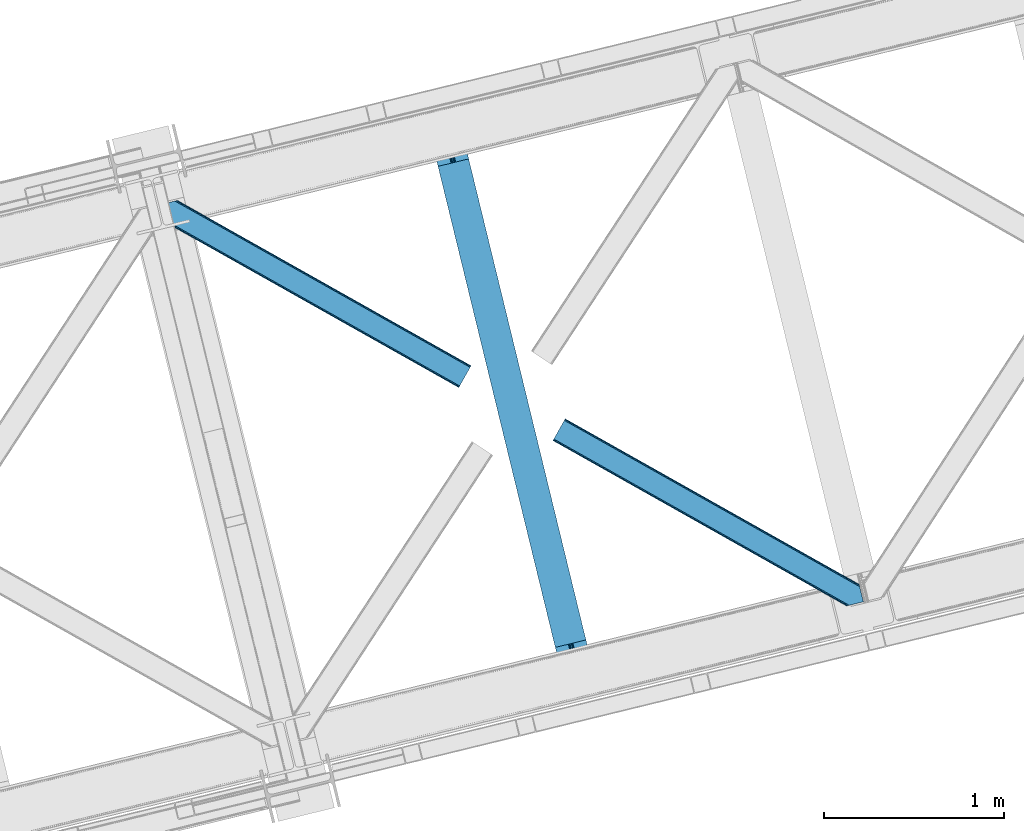
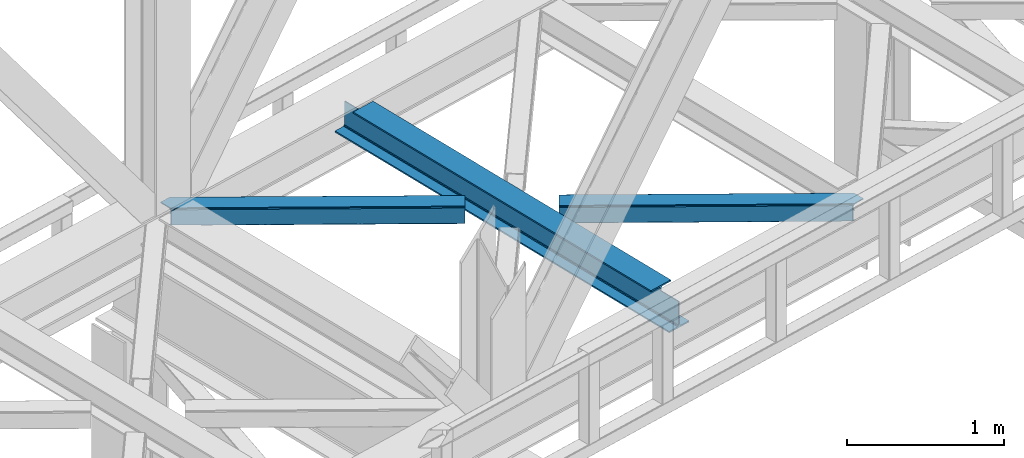
# One storey, part 52 of 93: 2 members, 1 beam.
"""IFC4 building model written with IfcOpenShell, lengths in millimetres."""

from ifc_helpers import new_model, entity, si_unit, converted_unit, derived_unit, direction, frame, origin, place, context, subcontext, project, spatial, triangles, polygons, material, type_object, element, save


model = new_model("IFC4")

# Units and contexts
model_context = context("Model", 3, precision=0.01, world=origin(), true_north=direction((6.12303176911189e-17, 1.0)))
plan_context = context("Plan", 3, precision=0.01, world=origin(), true_north=direction((6.12303176911189e-17, 1.0)))
body_context = subcontext(model_context, "Body", "Model", "MODEL_VIEW")
ifc_project = project(units=[si_unit("LENGTHUNIT", "METRE", prefix="MILLI"), si_unit("AREAUNIT", "SQUARE_METRE"), si_unit("VOLUMEUNIT", "CUBIC_METRE"), converted_unit("PLANEANGLEUNIT", "DEGREE", entity("IfcRatioMeasure", 0.0174532925199433), si_unit("PLANEANGLEUNIT", "RADIAN"), dimensions=[0, 0, 0, 0, 0, 0, 0]), si_unit("MASSUNIT", "GRAM", prefix="KILO"), derived_unit("MASSDENSITYUNIT", [(si_unit("MASSUNIT", "GRAM", prefix="KILO"), 1), (si_unit("LENGTHUNIT", "METRE"), -3)]), derived_unit("MOMENTOFINERTIAUNIT", [(si_unit("LENGTHUNIT", "METRE"), 4)]), si_unit("TIMEUNIT", "SECOND"), si_unit("FREQUENCYUNIT", "HERTZ"), si_unit("THERMODYNAMICTEMPERATUREUNIT", "DEGREE_CELSIUS"), derived_unit("THERMALTRANSMITTANCEUNIT", [(si_unit("MASSUNIT", "GRAM", prefix="KILO"), 1), (si_unit("THERMODYNAMICTEMPERATUREUNIT", "KELVIN"), -1), (si_unit("TIMEUNIT", "SECOND"), -3)]), derived_unit("VOLUMETRICFLOWRATEUNIT", [(si_unit("LENGTHUNIT", "METRE"), 3), (si_unit("TIMEUNIT", "SECOND"), -1)]), derived_unit("MASSFLOWRATEUNIT", [(si_unit("MASSUNIT", "GRAM", prefix="KILO"), 1), (si_unit("TIMEUNIT", "SECOND"), -1)]), derived_unit("ROTATIONALFREQUENCYUNIT", [(si_unit("TIMEUNIT", "SECOND"), -1)]), si_unit("ELECTRICCURRENTUNIT", "AMPERE"), si_unit("ELECTRICVOLTAGEUNIT", "VOLT"), si_unit("POWERUNIT", "WATT"), si_unit("FORCEUNIT", "NEWTON", prefix="KILO"), si_unit("ILLUMINANCEUNIT", "LUX"), si_unit("LUMINOUSFLUXUNIT", "LUMEN"), si_unit("LUMINOUSINTENSITYUNIT", "CANDELA"), derived_unit("USERDEFINED", [(si_unit("MASSUNIT", "GRAM", prefix="KILO"), -1), (si_unit("LENGTHUNIT", "METRE"), -2), (si_unit("TIMEUNIT", "SECOND"), 3), (si_unit("LUMINOUSFLUXUNIT", "LUMEN"), 1)]), derived_unit("LINEARVELOCITYUNIT", [(si_unit("LENGTHUNIT", "METRE"), 1), (si_unit("TIMEUNIT", "SECOND"), -1)]), si_unit("PRESSUREUNIT", "PASCAL"), derived_unit("USERDEFINED", [(si_unit("LENGTHUNIT", "METRE"), -2), (si_unit("MASSUNIT", "GRAM", prefix="KILO"), 1), (si_unit("TIMEUNIT", "SECOND"), -2)]), derived_unit("LINEARFORCEUNIT", [(si_unit("MASSUNIT", "GRAM", prefix="KILO"), 1), (si_unit("LENGTHUNIT", "METRE"), 1), (si_unit("TIMEUNIT", "SECOND"), -2), (si_unit("LENGTHUNIT", "METRE"), -1)]), derived_unit("PLANARFORCEUNIT", [(si_unit("MASSUNIT", "GRAM", prefix="KILO"), 1), (si_unit("LENGTHUNIT", "METRE"), 1), (si_unit("TIMEUNIT", "SECOND"), -2), (si_unit("LENGTHUNIT", "METRE"), -2)])], contexts=[model_context, plan_context])

# Site, building, storey
site_placement = place(None, origin())
site = spatial("IfcSite", under=ifc_project, at=site_placement, CompositionType="ELEMENT")
building_placement = place(site_placement, origin())
building = spatial("IfcBuilding", under=site, at=building_placement, CompositionType="ELEMENT")
storey_placement = place(building_placement, frame((0.0, 0.0, 15900.0)))
storey = spatial("IfcBuildingStorey", under=building, at=storey_placement, CompositionType="ELEMENT", Elevation=15900.0)

# Beam
ifc_material = material(Name="Metal painted (White)")
beam_type = type_object("IfcBeamType", PredefinedType="BEAM")
beam_placement = place(storey_placement, frame((-35007.0441659093, 9253.3674212464, 3441.0)))
element("IfcBeam", 1, at=beam_placement, inside=storey, type_object=beam_type, material=ifc_material, ObjectType="Steel Beam", PredefinedType="BEAM", context=body_context, shape_type="Tessellation", body=[
    polygons([(900.98534618944, 41.4445662733092, 11.000000000004), (900.98534618944, 41.444566273307, 2.16573425859679e-12), (170.021610174761, 3040.13999372697, 2.16573425859679e-12), (170.021610174761, 3040.13999372697, 11.000000000004), (834.919806235819, 25.3403919499645, 11.000000000004), (103.956070221148, 3024.03581940362, 11.000000000004), (828.971056214522, 23.8903211957374, 12.2179274798217), (98.007320199847, 3022.5857486494, 12.2179274798217), (823.927949458418, 22.6610105689162, 15.6862915010192), (92.9642134437384, 3021.35643802258, 15.6862915010192), (820.558253255242, 21.8396114687108, 20.8770650821657), (89.5945172405711, 3020.53503892237, 20.8770650821657), (819.374973305552, 21.5511744621195, 27.0000000000047), (88.4112372908766, 3020.24660191578, 27.0000000000047), (81.6103728838888, 3018.58881926485, 27.0000000000047), (81.6103728838888, 3018.58881926485, 203.000000000006), (88.4112372908766, 3020.24660191578, 203.000000000006), (4.33146851719357e-12, 2998.69542745366, 2.16573425859679e-12), (4.33146851719357e-12, 2998.69542745366, 10.9999999999997), (66.0655399536259, 3014.799601777, 11.000000000004), (72.0142899749184, 3016.24967253123, 12.2179274798217), (77.0573967310226, 3017.47898315805, 15.6862915010192), (80.4270929342029, 3018.30038225825, 20.8770650821657), (819.374973305556, 21.5511744621184, 203.000000000006), (812.574108898568, 19.8933918111886, 203.000000000006), (812.574108898564, 19.8933918111886, 27.0000000000047), (811.390828948882, 19.6049548045963, 20.8770650821657), (808.021132745702, 18.7835557043876, 15.6862915010192), (802.978025989598, 17.5542450775675, 12.2179274798217), (797.029275968301, 16.1041743233414, 11.000000000004), (730.963736014684, -1.08286712929839e-12, 10.9999999999997), (730.963736014684, -1.08286712929839e-12, 2.16573425859679e-12), (779.675212882762, 184.415062601691, 203.069791966819), (128.020401343512, 2857.75452019162, 203.000000000006), (128.243282132663, 2856.84017775719, 203.617301946336), (128.256196377186, 2856.7871977843, 217.000003693143), (779.530009633837, 185.01059740407, 217.000003676718), (779.530880241726, 185.00702596319, 204.00000679514), (772.964911718333, 182.385463974442, 203.006342981529), (772.742064056786, 183.299815969775, 203.617301946336), (772.729149812267, 183.352795942668, 217.000003693143), (121.455336555616, 2855.1293963229, 217.000003676718), (121.454465947718, 2855.13296776378, 204.00000679514), (121.310166358673, 2855.72494066435, 203.076120467494), (121.219536936524, 2856.09673754068, 203.000000000006), (780.713494357872, 185.298194377513, 223.122939328039), (784.082490766539, 186.122464201392, 228.313710402595), (789.125126170563, 187.353708426696, 231.78207273546), (795.073705041275, 188.804481281378, 232.999999602236), (861.139155906794, 204.909021065312, 232.999999283132), (861.137682570357, 204.915065042185, 243.999994005812), (691.116301666435, 163.469558245294, 243.999994827032), (691.117775002873, 163.463514268423, 233.000000104353), (757.183225868405, 179.568054052357, 232.999999785253), (763.132130996735, 181.017488520582, 231.782072861012), (768.175695503857, 182.244921343715, 228.313710479427), (771.546082413606, 183.063487001147, 223.12293937232), (120.271851831576, 2854.84179934945, 223.122939328039), (116.902855422901, 2854.01752952557, 228.313710402599), (111.860220018882, 2852.78628530027, 231.782072735464), (105.91164114817, 2851.33551244559, 232.999999602236), (39.8461902826462, 2835.23097266165, 232.999999283128), (39.8476636190837, 2835.22492868478, 243.999994005812), (209.869044523005, 2876.67043548167, 243.999994827032), (209.867571186567, 2876.67647945854, 233.000000104357), (143.802120321044, 2860.57193967461, 232.999999785253), (137.85321519271, 2859.12250520638, 231.782072861007), (132.809650685583, 2857.89507238325, 228.313710479427), (129.439263775843, 2857.07650672582, 223.12293937232)], [[[1, 2, 3, 4]], [[5, 1, 4, 6]], [[7, 5, 6, 8]], [[9, 7, 8, 10]], [[11, 9, 10, 12]], [[13, 11, 12, 14]], [[15, 16, 17, 14, 12, 10, 8, 6, 4, 3, 18, 19, 20, 21, 22, 23]], [[13, 24, 25, 26, 27, 28, 29, 30, 31, 32, 2, 1, 5, 7, 9, 11]], [[2, 32, 18, 3]], [[32, 31, 19, 18]], [[31, 30, 20, 19]], [[27, 26, 15, 23]], [[28, 27, 23, 22]], [[29, 28, 22, 21]], [[30, 29, 21, 20]], [[33, 24, 13, 14, 17, 34, 35, 36, 37, 38]], [[25, 39, 40, 41, 42, 43, 44, 16, 15, 26]], [[39, 25, 24, 33]], [[45, 34, 17, 16]], [[41, 40, 38, 37, 46, 47, 48, 49, 50, 51, 52, 53, 54, 55, 56, 57]], [[42, 58, 59, 60, 61, 62, 63, 64, 65, 66, 67, 68, 69, 36, 35, 43]], [[46, 37, 36, 69]], [[47, 46, 69, 68]], [[48, 47, 68, 67]], [[49, 48, 67, 66]], [[50, 49, 66, 65]], [[51, 50, 65, 64]], [[52, 51, 64, 63]], [[53, 52, 63, 62]], [[54, 53, 62, 61]], [[55, 54, 61, 60]], [[56, 55, 60, 59]], [[57, 56, 59, 58]], [[41, 57, 58, 42]]], closed=False),
])

# Members
member_type_1 = type_object("IfcMemberType", PredefinedType="BRACE")
member_1_placement = place(storey_placement, frame((-36508.3901733398, 10859.6510925293, 3511.0000579834)))
element("IfcMember", 2, at=member_1_placement, inside=storey, type_object=member_type_1, ObjectType="Steel Horizontal Brace", PredefinedType="BRACE", context=body_context, shape_type="Tessellation", body=[
    triangles([(1656.08961181641, 0.0, 122.500662231447), (1656.74538574219, 1.16155700683703, 129.197927856447), (23.8915649414048, 919.172964477539, 122.500662231447), (23.4590332031221, 920.946112060547, 129.197927856447), (1658.60573730469, 4.46600646972729, 134.874325561526), (22.2288757324204, 925.992315673828, 134.874325561526), (1661.39161376953, 9.41337890625073, 138.667117309571), (20.3871276855498, 933.544180297851, 138.667117309571), (1664.6774597168, 15.2490692138672, 139.999594116212), (18.2151672363252, 942.452938842775, 139.999594116212), (1656.08961181641, 0.0, 17.5000946044929), (23.8915649414048, 919.172964477539, 17.5000946044929), (1716.19989624024, 106.738833618165, 139.999594116212), (69.4469238281235, 1034.10780944824, 139.999594116212), (0.0, 1017.17977294922, 139.999594116212), (1719.4857421875, 112.573361206056, 138.667117309571), (78.971923828125, 1036.42976074219, 138.667117309571), (1722.27161865235, 117.520733642579, 134.874325561526), (87.0458496093779, 1038.39824523926, 134.874325561526), (1724.13197021485, 120.826345825195, 129.197927856447), (92.4408691406279, 1039.71328125, 129.197927856447), (1724.78774414062, 121.986740112305, 122.500662231447), (94.3384277343721, 1040.17488098145, 122.500662231447), (1724.78774414062, 121.986740112305, 17.5000946044929), (94.3384277343721, 1040.17488098145, 17.5000946044929), (1656.74538574219, 1.16155700683703, 10.8028289794929), (1658.60573730469, 4.46600646972729, 5.12526855468968), (196.057800292969, 824.821746826172, 8.8831787109375), (196.076403808591, 825.067080688477, 8.50064392089917), (23.3706665039063, 921.307717895508, 10.8691040039084), (195.064837646481, 824.999642944336, 9.50058288574292), (195.734564208986, 824.8798828125, 9.08316650390771), (23.263696289061, 921.748388671875, 9.50058288574292), (195.222967529298, 828.571517944336, 5.12526855468968), (1664.6774597168, 15.2490692138672, 0.0), (1661.39161376953, 9.41337890625073, 1.33247680664135), (193.38121948242, 836.123382568359, 1.33247680664135), (191.209259033203, 845.032141113281, 0.0), (1716.19989624024, 106.738833618165, 0.0), (157.162499999999, 984.711987304689, 0.0), (191.348785400391, 843.224111938476, 9.20757751465135), (191.292974853517, 844.069409179689, 8.85411071777344), (191.104614257813, 845.461184692384, 8.41343994140698), (18.8686157226548, 939.774032592773, 9.50058288574292), (1724.13197021485, 120.826345825195, 10.8028289794929), (92.0548461914077, 1039.61910095215, 10.8702667236357), (150.921020507813, 1006.08858947754, 9.50058288574292), (1722.27161865235, 117.520733642579, 5.12526855468968), (153.148791503903, 1001.17261047363, 5.12526855468968), (152.295355224611, 1004.67704772949, 8.50064392089917), (151.609350585939, 1005.38281860352, 9.00061340332104), (91.582781982419, 1039.50399169922, 9.50058288574292), (1719.4857421875, 112.573361206056, 1.33247680664135), (154.990539550781, 993.62074584961, 1.33247680664135), (156.250927734378, 986.702563476563, 9.11688537597729), (155.811419677731, 987.635064697266, 9.42384338378906), (156.692761230472, 985.761923217773, 8.80760192871094), (157.132269287111, 984.82942199707, 8.50064392089917), (155.316101074219, 988.062945556641, 9.50058288574292), (72.3118652343765, 1034.80660400391, 9.50058288574292), (159.43212890625, 975.399765014648, 6.99957275390625), (188.939630126952, 854.344363403321, 6.99957275390625), (1668.11213378907, 21.3475341796875, 6.99957275390625), (1712.76522216797, 100.639205932617, 6.99957275390625), (19.959246826169, 935.304537963868, 12.1260040283232), (1662.04041137695, 10.5656341552731, 12.1260040283232), (1664.8262878418, 15.5130065917965, 8.3320495605476), (1659.52661132813, 6.0996276855476, 24.4996673583992), (1660.18005981445, 7.26002197265734, 17.8035644531265), (21.6219360351533, 928.485186767579, 24.4996673583992), (21.1894042968779, 930.257171630859, 17.8035644531265), (1716.05106811524, 106.474896240235, 8.3320495605476), (1718.83694458008, 111.422268676759, 12.1260040283232), (77.0906433105483, 1035.9704864502, 12.1260040283232), (1720.69729614258, 114.726718139649, 17.8035644531265), (82.4856628417983, 1037.28552246094, 17.8035644531265), (1721.35074462891, 115.887112426759, 24.4996673583992), (84.3808959960952, 1037.74828491211, 24.4996673583992), (1659.52661132813, 6.0996276855476, 115.501089477541), (21.6219360351533, 928.485186767579, 115.501089477541), (21.1894042968779, 930.257171630859, 122.196029663086), (19.959246826169, 935.304537963868, 127.87475280762), (15.945538330081, 951.765161132813, 133.000021362306), (18.1174987792983, 942.856402587891, 131.667544555665), (0.0, 1017.17977294922, 133.000021362306), (1668.11213378907, 21.3475341796875, 133.000021362306), (1664.8262878418, 15.5130065917965, 131.667544555665), (1662.04041137695, 10.5656341552731, 127.87475280762), (1660.18005981445, 7.26002197265734, 122.196029663086), (1718.83694458008, 111.422268676759, 127.87475280762), (1720.69729614258, 114.726718139649, 122.196029663086), (1721.35074462891, 115.887112426759, 115.501089477541), (1712.76522216797, 100.639205932617, 133.000021362306), (1716.05106811524, 106.474896240235, 131.667544555665), (77.0906433105483, 1035.9704864502, 127.87475280762), (69.0143920898408, 1034.00316467285, 131.667544555665), (82.4856628417983, 1037.28552246094, 122.196029663086), (59.4893920898467, 1031.68121337891, 133.000021362306), (84.3808959960952, 1037.74828491211, 115.501089477541)], [[1, 2, 3], [4, 3, 2], [2, 5, 4], [6, 4, 5], [5, 7, 6], [8, 6, 7], [7, 9, 8], [10, 8, 9], [11, 1, 3], [3, 12, 11], [13, 10, 9], [10, 13, 14], [15, 10, 14], [13, 16, 17], [17, 14, 13], [16, 18, 19], [19, 17, 16], [18, 20, 21], [21, 19, 18], [20, 22, 23], [23, 21, 20], [22, 24, 25], [25, 23, 22], [26, 11, 12], [27, 28, 29], [26, 30, 31], [31, 27, 26], [31, 32, 27], [30, 33, 31], [29, 34, 27], [35, 36, 37], [37, 38, 35], [36, 27, 34], [34, 37, 36], [12, 30, 26], [39, 35, 38], [38, 40, 39], [41, 42, 29], [42, 43, 29], [41, 31, 33], [33, 44, 41], [45, 46, 25], [46, 45, 47], [45, 48, 49], [49, 50, 45], [45, 50, 51], [51, 47, 45], [47, 52, 46], [48, 53, 54], [54, 49, 48], [53, 39, 40], [40, 54, 53], [25, 24, 45], [51, 55, 56], [50, 57, 55], [50, 58, 57], [47, 59, 52], [60, 52, 59], [61, 40, 62], [54, 58, 49], [58, 54, 40], [49, 58, 50], [40, 61, 58], [62, 40, 38], [37, 43, 38], [43, 37, 34], [38, 43, 62], [34, 29, 43], [63, 64, 62], [61, 62, 64], [63, 62, 43], [41, 65, 66], [41, 44, 65], [43, 66, 67], [66, 43, 42], [42, 41, 66], [43, 67, 63], [68, 69, 70], [71, 70, 69], [69, 66, 71], [65, 71, 66], [72, 58, 61], [57, 72, 55], [57, 58, 72], [56, 55, 72], [73, 74, 59], [59, 72, 73], [74, 60, 59], [73, 75, 76], [76, 74, 73], [75, 77, 78], [78, 76, 75], [61, 64, 72], [79, 68, 80], [70, 80, 68], [81, 6, 82], [80, 70, 3], [4, 81, 3], [81, 4, 6], [81, 80, 3], [70, 12, 3], [71, 65, 33], [33, 30, 71], [30, 12, 71], [70, 71, 12], [83, 10, 15], [10, 84, 8], [84, 10, 83], [15, 85, 83], [84, 82, 8], [44, 33, 65], [8, 82, 6], [86, 87, 84], [84, 83, 86], [87, 88, 82], [82, 84, 87], [88, 89, 81], [81, 82, 88], [89, 79, 80], [80, 81, 89], [20, 90, 91], [92, 24, 22], [20, 91, 22], [20, 18, 90], [91, 92, 22], [90, 18, 16], [93, 13, 9], [13, 94, 16], [94, 13, 93], [94, 90, 16], [45, 73, 48], [77, 24, 92], [24, 75, 45], [75, 24, 77], [45, 75, 73], [39, 64, 35], [53, 48, 73], [73, 72, 53], [72, 64, 39], [39, 53, 72], [88, 7, 5], [9, 86, 93], [9, 87, 86], [87, 9, 7], [88, 87, 7], [79, 1, 11], [2, 89, 88], [5, 2, 88], [89, 2, 1], [79, 89, 1], [36, 66, 27], [35, 64, 63], [63, 67, 35], [67, 66, 36], [36, 35, 67], [26, 27, 66], [11, 68, 79], [69, 11, 26], [11, 69, 68], [69, 26, 66], [95, 96, 17], [19, 95, 17], [19, 21, 97], [95, 19, 97], [97, 21, 23], [96, 14, 17], [15, 98, 85], [15, 14, 98], [96, 98, 14], [97, 23, 99], [78, 25, 76], [23, 78, 99], [25, 46, 76], [23, 25, 78], [52, 76, 46], [74, 76, 52], [60, 74, 52], [93, 83, 98], [93, 86, 83], [83, 85, 98], [77, 92, 78], [99, 78, 92], [92, 91, 99], [97, 99, 91], [91, 90, 97], [95, 97, 90], [90, 94, 95], [96, 95, 94], [94, 93, 96], [98, 96, 93]]),
])
member_type_2 = type_object("IfcMemberType", PredefinedType="BRACE")
member_2_placement = place(storey_placement, frame((-34329.4999145508, 9647.04894561768, 3511.0000579834)))
element("IfcMember", 3, at=member_2_placement, inside=storey, type_object=member_type_2, ObjectType="Steel Horizontal Brace", PredefinedType="BRACE", context=body_context, shape_type="Tessellation", body=[
    triangles([(1645.8158203125, 3.74570159912037, 138.667117309571), (1655.3408203125, 6.06765289306531, 139.999594116212), (8.58552246094041, 933.435466003417, 139.999594116212), (5.29967651367042, 927.600938415528, 138.667117309571), (1637.7395690918, 1.77663574218786, 134.874325561526), (2.51380004882958, 922.653565979004, 134.874325561526), (1632.34454956055, 0.461599731444949, 129.197927856447), (0.65344848632958, 919.347953796387, 129.197927856447), (1630.4516418457, 0.0, 122.500662231447), (0.0, 918.187559509277, 122.500662231447), (1630.4516418457, 0.0, 17.5000946044929), (0.0, 918.187559509277, 17.5000946044929), (1706.5725769043, 97.7219421386708, 139.999594116212), (1724.78774414062, 22.9956893920898, 139.999594116212), (60.1102844238267, 1024.92639312744, 139.999594116212), (1701.3287109375, 119.229350280761, 129.197927856447), (1700.89617919922, 121.001335144043, 122.500662231447), (68.0446838378921, 1039.01390533447, 129.197927856447), (68.6958068847671, 1040.17429962158, 122.500662231447), (1702.5588684082, 114.183146667479, 134.874325561526), (66.1820068359375, 1035.70829315185, 134.874325561526), (1704.40061645508, 106.63011932373, 138.667117309571), (63.3961303710967, 1030.76092071533, 138.667117309571), (1700.89617919922, 121.001335144043, 17.5000946044929), (68.6958068847671, 1040.17429962158, 17.5000946044929), (0.65344848632958, 919.347953796387, 10.8028289794929), (1633.02822875977, 0.628450012207395, 10.9377044677749), (2.51380004882958, 922.653565979004, 5.12526855468968), (5.29967651367042, 927.600938415528, 1.33247680664135), (1569.79720458984, 46.5547164916989, 1.33247680664135), (1573.68999023438, 34.8100845336903, 8.52041015625218), (1571.51337890625, 39.517936706543, 5.59500732422021), (1572.28775024414, 36.3402236938473, 7.52047119140843), (1573.35047607422, 35.1809921264648, 8.278564453125), (1572.99003295898, 35.5751541137688, 8.02044067383031), (1572.6272644043, 35.9693161010746, 7.76231689453198), (1633.97700805664, 0.859831237792605, 8.52041015625218), (1567.62756958008, 55.4634750366204, 0.0), (8.58552246094041, 933.435466003417, 0.0), (1533.57848510742, 195.142158508301, 0.0), (60.1102844238267, 1024.92639312744, 0.0), (1566.72994995117, 59.1411575317379, 7.52047119140843), (1567.24852294922, 57.3430114746097, 7.90300598144677), (1567.78569946289, 56.436090087891, 8.1076446533225), (1568.32520141602, 55.5198669433594, 8.31460876464917), (1568.41124267578, 55.3762710571282, 8.3471649169951), (1568.86237792969, 54.6129455566406, 8.52041015625218), (1655.15013427734, 6.02056274414099, 8.52041015625218), (5.95079956054542, 928.75319366455, 12.1260040283232), (1647.69710083008, 4.20381317138708, 12.1260040283232), (8.73435058593896, 933.699403381348, 8.3320495605476), (12.0225219726563, 939.535093688964, 6.99957275390625), (1565.35794067383, 64.7751159667969, 6.99957275390625), (1642.29975585937, 2.88877716064417, 17.8035644531265), (4.08812255859084, 925.447581481933, 17.8035644531265), (1640.40452270508, 2.42659606933557, 24.4996673583992), (3.43467407226854, 924.287187194825, 24.4996673583992), (1640.40452270508, 2.42659606933557, 115.501089477541), (3.43467407226854, 924.287187194825, 115.501089477541), (1647.69710083008, 4.20381317138708, 127.87475280762), (1655.77102661133, 6.17229766845594, 131.667544555665), (1642.29975585937, 2.88877716064417, 122.196029663086), (1665.29602661133, 8.49366760253906, 133.000021362306), (1724.78774414062, 22.9956893920898, 133.000021362306), (4.08812255859084, 925.447581481933, 122.196029663086), (5.95079956054542, 928.75319366455, 127.87475280762), (8.73435058593896, 933.699403381348, 131.667544555665), (12.0225219726563, 939.535093688964, 133.000021362306), (1708.84220581055, 88.4097198486324, 133.000021362306), (56.6732849121108, 1018.82676544189, 133.000021362306), (1535.84811401367, 185.831098937988, 6.99957275390625), (56.6732849121108, 1018.82676544189, 6.99957275390625), (68.0446838378921, 1039.01390533447, 10.8028289794929), (62.747332763669, 1029.60866546631, 12.1260040283232), (64.6100097656235, 1032.91427764893, 17.8035644531265), (65.2611328124985, 1034.07467193603, 24.4996673583992), (66.1820068359375, 1035.70829315185, 5.12526855468968), (63.3961303710967, 1030.76092071533, 1.33247680664135), (59.9614562988281, 1024.66245574951, 8.3320495605476), (62.747332763669, 1029.60866546631, 127.87475280762), (65.2611328124985, 1034.07467193603, 115.501089477541), (64.6100097656235, 1032.91427764893, 122.196029663086), (59.9614562988281, 1024.66245574951, 131.667544555665), (1703.16813354492, 111.689112854003, 24.4996673583992), (1703.16813354492, 111.689112854003, 115.501089477541), (1706.67024536133, 97.318478393554, 131.667544555665), (1704.82849731445, 104.870924377441, 127.87475280762), (1703.59833984375, 109.917127990722, 122.196029663086), (1704.82849731445, 104.870924377441, 12.1260040283232), (1706.52839355469, 97.9004196166989, 8.52041015625218), (1701.70078125, 117.702699279786, 8.52041015625218), (1703.59833984375, 109.917127990722, 17.8035644531265), (1701.48451538086, 118.591017150879, 10.9365417480476), (1534.47610473633, 191.464476013183, 7.52047119140843), (1529.69267578125, 211.087696838378, 5.59500732422021), (1528.9159790039, 214.266572570801, 7.52047119140843), (1531.4065246582, 204.050917053222, 1.33247680664135), (1529.11596679688, 214.688639831542, 8.22740478515698), (1529.01597290039, 214.477024841308, 7.87393798828271), (1529.89963989258, 214.452607727051, 8.52041015625218), (1534.35053100586, 192.705097961425, 7.85649719238427), (1534.72725219726, 194.649165344237, 8.52041015625218)], [[1, 2, 3], [3, 4, 1], [5, 1, 4], [4, 6, 5], [7, 5, 6], [6, 8, 7], [9, 7, 8], [8, 10, 9], [11, 9, 12], [10, 12, 9], [2, 13, 3], [2, 14, 13], [15, 3, 13], [16, 17, 18], [19, 18, 17], [20, 16, 21], [18, 21, 16], [22, 20, 23], [21, 23, 20], [13, 22, 15], [23, 15, 22], [17, 24, 19], [25, 19, 24], [26, 27, 11], [28, 29, 30], [27, 26, 31], [26, 28, 32], [32, 33, 26], [34, 26, 35], [34, 31, 26], [26, 36, 35], [26, 33, 36], [31, 37, 27], [30, 32, 28], [38, 30, 29], [29, 39, 38], [11, 12, 26], [40, 38, 39], [39, 41, 40], [33, 42, 43], [36, 43, 44], [35, 44, 45], [34, 46, 47], [34, 45, 46], [47, 31, 34], [45, 34, 35], [44, 35, 36], [43, 36, 33], [48, 37, 47], [31, 47, 37], [49, 50, 47], [47, 51, 49], [47, 46, 51], [50, 48, 47], [52, 43, 42], [51, 46, 45], [45, 52, 51], [45, 44, 52], [43, 52, 44], [42, 53, 52], [54, 50, 49], [49, 55, 54], [56, 54, 55], [55, 57, 56], [58, 56, 59], [57, 59, 56], [60, 61, 1], [5, 60, 1], [5, 7, 62], [60, 5, 62], [62, 7, 9], [61, 2, 1], [14, 63, 64], [14, 2, 63], [61, 63, 2], [62, 9, 58], [56, 11, 54], [9, 56, 58], [11, 27, 54], [9, 11, 56], [37, 54, 27], [50, 54, 37], [48, 50, 37], [62, 58, 65], [59, 65, 58], [60, 62, 66], [65, 66, 62], [61, 60, 67], [66, 67, 60], [63, 61, 68], [67, 68, 61], [69, 63, 68], [63, 69, 64], [68, 70, 69], [53, 71, 52], [72, 52, 71], [73, 74, 75], [76, 19, 25], [73, 75, 25], [73, 77, 74], [75, 76, 25], [74, 77, 78], [72, 41, 39], [41, 79, 78], [79, 41, 72], [79, 74, 78], [18, 80, 21], [81, 19, 76], [19, 82, 18], [82, 19, 81], [18, 82, 80], [15, 70, 3], [23, 21, 80], [80, 83, 23], [83, 70, 15], [15, 23, 83], [49, 29, 28], [39, 52, 72], [39, 51, 52], [51, 39, 29], [49, 51, 29], [57, 12, 10], [26, 55, 49], [28, 26, 49], [55, 26, 12], [57, 55, 12], [4, 66, 6], [3, 70, 68], [68, 67, 3], [67, 66, 4], [4, 3, 67], [8, 6, 66], [10, 59, 57], [65, 10, 8], [10, 65, 59], [65, 8, 66], [84, 85, 76], [81, 76, 85], [86, 69, 70], [70, 83, 86], [87, 86, 83], [83, 80, 87], [88, 87, 80], [80, 82, 88], [85, 88, 82], [82, 81, 85], [87, 20, 22], [89, 90, 91], [20, 87, 88], [86, 87, 22], [86, 13, 69], [14, 69, 13], [69, 14, 64], [86, 22, 13], [24, 17, 84], [91, 92, 89], [92, 24, 84], [93, 92, 91], [93, 24, 92], [17, 85, 84], [88, 16, 20], [17, 16, 88], [85, 17, 88], [40, 71, 53], [94, 95, 96], [40, 94, 71], [94, 97, 95], [94, 40, 97], [38, 40, 53], [42, 38, 53], [32, 42, 33], [42, 30, 38], [42, 32, 30], [73, 25, 24], [98, 99, 77], [96, 77, 99], [96, 95, 77], [73, 93, 100], [100, 77, 73], [100, 98, 77], [93, 91, 100], [78, 77, 95], [97, 40, 41], [41, 78, 97], [95, 97, 78], [24, 93, 73], [72, 71, 94], [94, 79, 72], [101, 102, 79], [79, 94, 101], [74, 79, 102], [90, 89, 102], [74, 102, 89], [92, 84, 75], [76, 75, 84], [89, 92, 74], [75, 74, 92], [101, 94, 99], [102, 101, 99], [91, 90, 102], [102, 100, 91]]),
])

save(model, "model.ifc")
